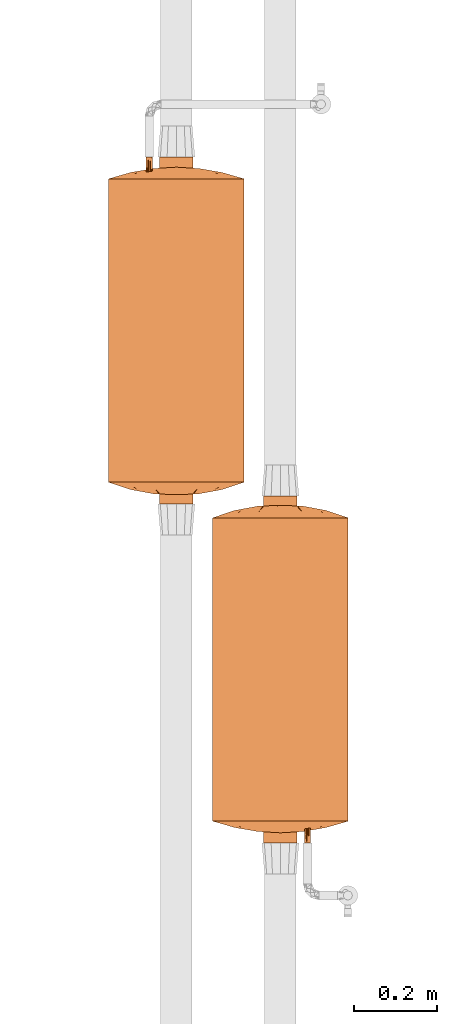
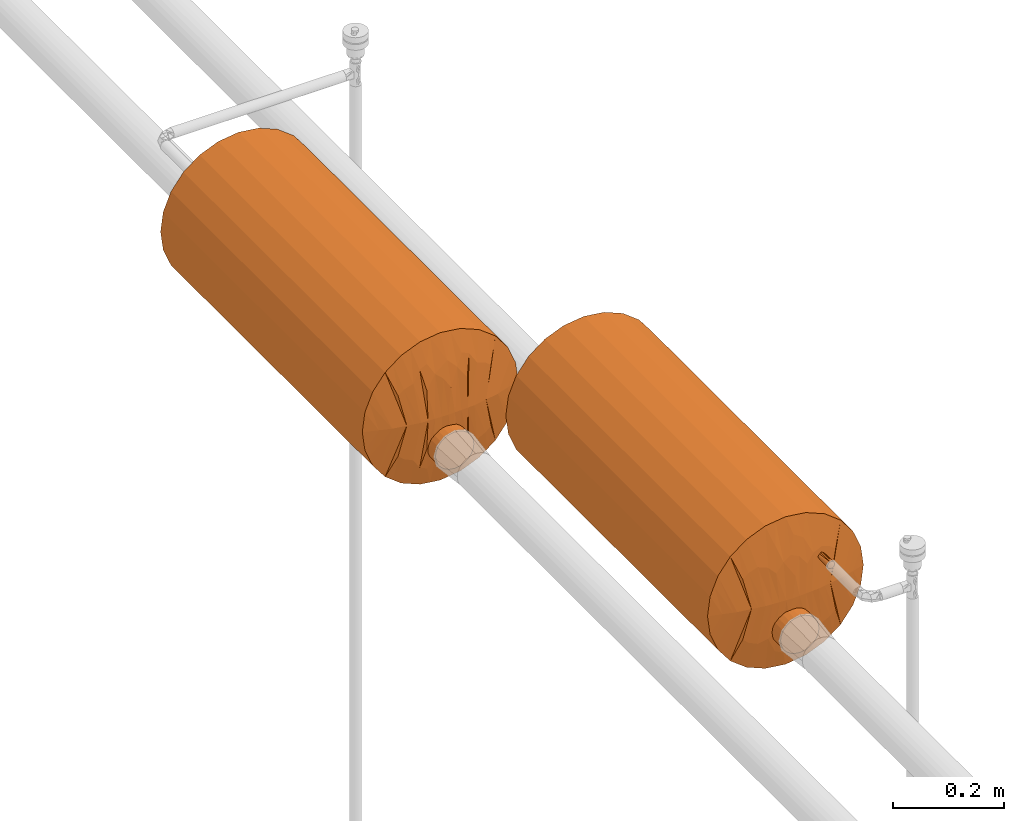
# One storey, part 826 of 827: 2 proxies.
"""IFC2X3 building model written with IfcOpenShell, lengths in millimetres."""

from ifc_helpers import new_model, entity, si_unit, converted_unit, derived_unit, direction, frame, origin, place, context, subcontext, project, spatial, faceted_brep, source, transform, mapped, material, material_list, type_object, type_shapes, element, save


model = new_model("IFC2X3")

# Units and contexts
model_context = context("Model", 3, precision=0.01, world=origin(), true_north=direction((6.12303176911189e-17, 1.0)))
body_context = subcontext(model_context, "Body", "Model", "MODEL_VIEW")
ifc_project = project(units=[si_unit("LENGTHUNIT", "METRE", prefix="MILLI"), si_unit("AREAUNIT", "SQUARE_METRE"), si_unit("VOLUMEUNIT", "CUBIC_METRE"), converted_unit("PLANEANGLEUNIT", "DEGREE", entity("IfcRatioMeasure", 0.0174532925199433), si_unit("PLANEANGLEUNIT", "RADIAN"), dimensions=[0, 0, 0, 0, 0, 0, 0]), si_unit("MASSUNIT", "GRAM", prefix="KILO"), derived_unit("MASSDENSITYUNIT", [(si_unit("MASSUNIT", "GRAM", prefix="KILO"), 1), (si_unit("LENGTHUNIT", "METRE"), -3)]), derived_unit("MOMENTOFINERTIAUNIT", [(si_unit("LENGTHUNIT", "METRE"), 4)]), si_unit("TIMEUNIT", "SECOND"), si_unit("FREQUENCYUNIT", "HERTZ"), si_unit("THERMODYNAMICTEMPERATUREUNIT", "DEGREE_CELSIUS"), derived_unit("THERMALTRANSMITTANCEUNIT", [(si_unit("MASSUNIT", "GRAM", prefix="KILO"), 1), (si_unit("THERMODYNAMICTEMPERATUREUNIT", "KELVIN"), -1), (si_unit("TIMEUNIT", "SECOND"), -3)]), derived_unit("VOLUMETRICFLOWRATEUNIT", [(si_unit("LENGTHUNIT", "METRE"), 3), (si_unit("TIMEUNIT", "SECOND"), -1)]), derived_unit("MASSFLOWRATEUNIT", [(si_unit("MASSUNIT", "GRAM", prefix="KILO"), 1), (si_unit("TIMEUNIT", "SECOND"), -1)]), derived_unit("ROTATIONALFREQUENCYUNIT", [(si_unit("TIMEUNIT", "SECOND"), -1)]), si_unit("ELECTRICCURRENTUNIT", "AMPERE"), si_unit("ELECTRICVOLTAGEUNIT", "VOLT"), si_unit("POWERUNIT", "WATT"), si_unit("FORCEUNIT", "NEWTON", prefix="KILO"), si_unit("ILLUMINANCEUNIT", "LUX"), si_unit("LUMINOUSFLUXUNIT", "LUMEN"), si_unit("LUMINOUSINTENSITYUNIT", "CANDELA"), derived_unit("USERDEFINED", [(si_unit("MASSUNIT", "GRAM", prefix="KILO"), -1), (si_unit("LENGTHUNIT", "METRE"), -2), (si_unit("TIMEUNIT", "SECOND"), 3), (si_unit("LUMINOUSFLUXUNIT", "LUMEN"), 1)]), derived_unit("LINEARVELOCITYUNIT", [(si_unit("LENGTHUNIT", "METRE"), 1), (si_unit("TIMEUNIT", "SECOND"), -1)]), si_unit("PRESSUREUNIT", "PASCAL"), derived_unit("USERDEFINED", [(si_unit("LENGTHUNIT", "METRE"), -2), (si_unit("MASSUNIT", "GRAM", prefix="KILO"), 1), (si_unit("TIMEUNIT", "SECOND"), -2)]), derived_unit("LINEARFORCEUNIT", [(si_unit("MASSUNIT", "GRAM", prefix="KILO"), 1), (si_unit("LENGTHUNIT", "METRE"), 1), (si_unit("TIMEUNIT", "SECOND"), -2), (si_unit("LENGTHUNIT", "METRE"), -1)]), derived_unit("PLANARFORCEUNIT", [(si_unit("MASSUNIT", "GRAM", prefix="KILO"), 1), (si_unit("LENGTHUNIT", "METRE"), 1), (si_unit("TIMEUNIT", "SECOND"), -2), (si_unit("LENGTHUNIT", "METRE"), -2)])], contexts=[model_context])

# Site, building, storey
site_placement = place(None, origin())
site = spatial("IfcSite", under=ifc_project, at=site_placement, CompositionType="ELEMENT")
building_placement = place(site_placement, origin())
building = spatial("IfcBuilding", under=site, at=building_placement, CompositionType="ELEMENT")
storey_placement = place(building_placement, frame((0.0, 0.0, 28200.0)))
storey = spatial("IfcBuildingStorey", under=building, at=storey_placement, Name="08", CompositionType="ELEMENT", Elevation=28200.0)

# Proxies
ifc_material_1 = material()
ifc_material_2 = material()
ifc_material_3 = material()
ifc_material_list = material_list([ifc_material_1, ifc_material_2, ifc_material_3])
building_element_proxy_type = type_object("IfcBuildingElementProxyType", Name=":Dy80", PredefinedType="NOTDEFINED", material=ifc_material_1)
shared_shape = source(origin(), body_context, "Body", "Brep", [
    faceted_brep([(68.75, -416.0, 58.5), (70.3, -416.0, 59.7), (71.5, -416.0, 61.25), (72.24, -416.0, 63.06), (72.5, -416.0, 65.0), (72.24, -416.0, 66.94), (71.5, -416.0, 68.75), (70.3, -416.0, 70.3), (68.75, -416.0, 71.5), (66.94, -416.0, 72.24), (65.0, -416.0, 72.5), (63.06, -416.0, 72.24), (61.25, -416.0, 71.5), (59.7, -416.0, 70.3), (58.5, -416.0, 68.75), (57.76, -416.0, 66.94), (57.5, -416.0, 65.0), (57.76, -416.0, 63.06), (58.5, -416.0, 61.25), (59.7, -416.0, 59.7), (61.25, -416.0, 58.5), (63.06, -416.0, 57.76), (65.0, -416.0, 57.5), (66.94, -416.0, 57.76), (65.0, 0.0, 72.5), (66.94, 0.0, 72.24), (68.75, 0.0, 71.5), (70.3, 0.0, 70.3), (71.5, 0.0, 68.75), (72.24, 0.0, 66.94), (72.5, 0.0, 65.0), (72.24, 0.0, 63.06), (71.5, 0.0, 61.25), (70.3, 0.0, 59.7), (68.75, 0.0, 58.5), (66.94, 0.0, 57.76), (65.0, 0.0, 57.5), (63.06, 0.0, 57.76), (61.25, 0.0, 58.5), (59.7, 0.0, 59.7), (58.5, 0.0, 61.25), (57.76, 0.0, 63.06), (57.5, 0.0, 65.0), (57.76, 0.0, 66.94), (58.5, 0.0, 68.75), (59.7, 0.0, 70.3), (61.25, 0.0, 71.5), (63.06, 0.0, 72.24), (72.5, -320.38, 65.0), (65.49, -181.32, 57.52), (72.5, -95.62, 65.0), (72.5, -208.0, 65.0), (72.5, -224.75, 65.0), (65.0, -272.56, 57.5), (57.5, -320.38, 65.0), (57.5, -224.75, 65.0), (57.5, -208.0, 65.0), (65.0, -84.55, 57.5), (57.5, -95.62, 65.0), (65.0, -84.55, 72.5), (65.0, -272.56, 72.5), (64.51, -181.32, 72.48)], [[[0, 1, 2, 3, 4, 5, 6, 7, 8, 9, 10, 11, 12, 13, 14, 15, 16, 17, 18, 19, 20, 21, 22, 23]], [[24, 25, 26, 27, 28, 29, 30, 31, 32, 33, 34, 35, 36, 37, 38, 39, 40, 41, 42, 43, 44, 45, 46, 47]], [[48, 1, 0]], [[49, 50, 51, 52]], [[53, 54, 55, 56]], [[57, 38, 37]], [[2, 1, 48]], [[36, 57, 37]], [[21, 53, 22]], [[19, 18, 54]], [[58, 40, 39]], [[35, 34, 57]], [[58, 57, 49]], [[58, 42, 41]], [[17, 16, 54]], [[58, 49, 56]], [[18, 17, 54]], [[56, 49, 53]], [[48, 4, 3]], [[31, 30, 50]], [[38, 57, 39]], [[33, 57, 34]], [[53, 52, 48]], [[40, 58, 41]], [[33, 32, 50]], [[49, 57, 50]], [[50, 32, 31]], [[58, 39, 57]], [[52, 53, 49]], [[2, 48, 3]], [[35, 57, 36]], [[22, 53, 23]], [[54, 20, 19]], [[53, 48, 23]], [[0, 23, 48]], [[54, 53, 21]], [[21, 20, 54]], [[33, 50, 57]], [[13, 12, 54]], [[59, 26, 25]], [[14, 13, 54]], [[24, 59, 25]], [[9, 60, 10]], [[50, 28, 27]], [[47, 46, 59]], [[61, 58, 56, 55]], [[60, 55, 54]], [[50, 59, 61]], [[50, 30, 29]], [[5, 4, 48]], [[48, 7, 6]], [[48, 6, 5]], [[54, 16, 15]], [[43, 42, 58]], [[60, 51, 61]], [[50, 61, 51]], [[59, 46, 45]], [[26, 59, 27]], [[45, 44, 58]], [[60, 48, 52, 51]], [[61, 59, 58]], [[58, 44, 43]], [[59, 50, 27]], [[60, 61, 55]], [[14, 54, 15]], [[10, 60, 11]], [[47, 59, 24]], [[48, 8, 7]], [[60, 54, 11]], [[12, 11, 54]], [[9, 48, 60]], [[9, 8, 48]], [[28, 50, 29]], [[45, 58, 59]]]),
    faceted_brep([(10.24, -416.0, -103.64), (19.88, -416.0, -99.64), (28.17, -416.0, -93.28), (34.52, -416.0, -85.0), (38.52, -416.0, -75.35), (39.88, -416.0, -65.0), (38.52, -416.0, -54.65), (34.52, -416.0, -45.0), (28.17, -416.0, -36.72), (19.88, -416.0, -30.36), (10.24, -416.0, -26.36), (-0.12, -416.0, -25.0), (-10.47, -416.0, -26.36), (-20.12, -416.0, -30.36), (-28.4, -416.0, -36.72), (-34.76, -416.0, -45.0), (-38.75, -416.0, -54.65), (-40.12, -416.0, -65.0), (-38.75, -416.0, -75.35), (-34.76, -416.0, -85.0), (-28.4, -416.0, -93.28), (-20.12, -416.0, -99.64), (-10.47, -416.0, -103.64), (-0.12, -416.0, -105.0), (-0.12, 416.0, -25.0), (10.24, 416.0, -26.36), (19.88, 416.0, -30.36), (28.17, 416.0, -36.72), (34.52, 416.0, -45.0), (38.52, 416.0, -54.65), (39.88, 416.0, -65.0), (38.52, 416.0, -75.35), (34.52, 416.0, -85.0), (28.17, 416.0, -93.28), (19.88, 416.0, -99.64), (10.24, 416.0, -103.64), (-0.12, 416.0, -105.0), (-10.47, 416.0, -103.64), (-20.12, 416.0, -99.64), (-28.4, 416.0, -93.28), (-34.76, 416.0, -85.0), (-38.75, 416.0, -75.35), (-40.12, 416.0, -65.0), (-38.75, 416.0, -54.65), (-34.76, 416.0, -45.0), (-28.4, 416.0, -36.72), (-20.12, 416.0, -30.36), (-10.47, 416.0, -26.36), (-37.07, 0.0, -80.31), (-15.42, 0.0, -101.96), (-5.34, -184.0, -104.66), (-24.47, -103.67, -96.73), (-31.85, -184.0, -89.35), (-31.85, 103.67, -89.35), (-24.47, 184.0, -96.73), (24.23, 103.67, -96.73), (31.62, 184.0, -89.35), (24.23, -184.0, -96.73), (31.62, -103.67, -89.35), (-5.34, 103.67, -104.66), (-39.35, 138.45, -72.8), (-40.12, 0.0, -65.0), (-39.41, -146.88, -72.49), (5.1, -103.67, -104.66), (5.1, 184.0, -104.66), (15.19, 0.0, -101.96), (36.84, 0.0, -80.31), (39.88, 0.0, -65.0), (39.17, 146.88, -72.49), (39.11, -138.45, -72.8), (39.88, -25.67, -65.0), (24.23, -184.0, -33.27), (31.62, 0.0, -40.65), (36.84, 184.0, -49.69), (15.19, 0.0, -28.04), (24.23, 103.67, -33.27), (-24.47, 103.67, -33.27), (-31.85, 184.0, -40.65), (-24.47, -184.0, -33.27), (-31.85, -103.67, -40.65), (5.1, 103.67, -25.34), (39.15, -107.63, -57.39), (39.29, 153.03, -58.11), (36.84, -103.67, -49.69), (5.1, -184.0, -25.34), (-15.42, 0.0, -28.04), (-5.34, 184.0, -25.34), (-5.34, -103.67, -25.34), (-37.07, 0.0, -49.69), (-39.41, 146.88, -57.51), (-39.35, -138.45, -57.2)], [[[0, 1, 2, 3, 4, 5, 6, 7, 8, 9, 10, 11, 12, 13, 14, 15, 16, 17, 18, 19, 20, 21, 22, 23]], [[24, 25, 26, 27, 28, 29, 30, 31, 32, 33, 34, 35, 36, 37, 38, 39, 40, 41, 42, 43, 44, 45, 46, 47]], [[48, 41, 40]], [[49, 50, 22]], [[51, 52, 53, 54]], [[40, 53, 48]], [[49, 38, 37]], [[55, 33, 56]], [[57, 58, 2]], [[54, 49, 51]], [[48, 52, 19]], [[59, 49, 37]], [[41, 48, 60]], [[17, 61, 62]], [[41, 60, 42]], [[40, 39, 53]], [[51, 21, 20]], [[19, 18, 48]], [[63, 0, 23]], [[48, 53, 52]], [[21, 51, 49]], [[34, 33, 55]], [[22, 21, 49]], [[37, 36, 59]], [[49, 59, 50]], [[63, 50, 59, 64]], [[65, 35, 34]], [[59, 36, 64]], [[50, 63, 23]], [[34, 55, 65]], [[66, 32, 31]], [[33, 32, 56]], [[53, 39, 54]], [[56, 66, 58]], [[1, 57, 2]], [[30, 67, 68]], [[65, 0, 63]], [[1, 0, 65]], [[39, 38, 54]], [[58, 3, 2]], [[61, 60, 62]], [[65, 55, 57]], [[22, 50, 23]], [[66, 3, 58]], [[3, 66, 4]], [[36, 35, 64]], [[66, 69, 4]], [[19, 52, 20]], [[52, 51, 20]], [[65, 63, 64]], [[67, 69, 68]], [[69, 5, 4]], [[49, 54, 38]], [[65, 57, 1]], [[58, 57, 55, 56]], [[65, 64, 35]], [[66, 56, 32]], [[62, 48, 18]], [[42, 60, 61]], [[48, 62, 60]], [[17, 62, 18]], [[68, 66, 31]], [[69, 67, 70, 5]], [[66, 68, 69]], [[30, 68, 31]], [[9, 8, 71]], [[72, 73, 28]], [[74, 71, 75]], [[27, 72, 28]], [[74, 26, 25]], [[76, 45, 77]], [[78, 79, 14]], [[72, 27, 75]], [[72, 71, 8]], [[80, 74, 25]], [[5, 70, 81]], [[29, 73, 82]], [[46, 45, 76]], [[27, 26, 75]], [[83, 7, 6]], [[72, 7, 83]], [[72, 83, 73]], [[8, 7, 72]], [[71, 72, 75]], [[25, 24, 80]], [[10, 9, 74]], [[82, 30, 29]], [[74, 80, 84]], [[83, 81, 82]], [[85, 47, 46]], [[80, 24, 86]], [[84, 87, 11]], [[46, 76, 85]], [[88, 44, 43]], [[45, 44, 77]], [[10, 84, 11]], [[77, 88, 79]], [[13, 78, 14]], [[42, 61, 89]], [[85, 12, 87]], [[13, 12, 85]], [[79, 15, 14]], [[90, 17, 16]], [[74, 9, 71]], [[85, 76, 78]], [[28, 73, 29]], [[88, 15, 79]], [[15, 88, 16]], [[82, 81, 70]], [[88, 90, 16]], [[26, 74, 75]], [[24, 47, 86]], [[85, 87, 86]], [[61, 90, 89]], [[87, 12, 11]], [[83, 82, 73]], [[82, 70, 67, 30]], [[83, 6, 81]], [[5, 81, 6]], [[74, 84, 10]], [[87, 84, 80, 86]], [[85, 78, 13]], [[79, 78, 76]], [[85, 86, 47]], [[88, 77, 44]], [[76, 77, 79]], [[89, 88, 43]], [[17, 90, 61]], [[88, 89, 90]], [[42, 89, 43]]]),
    faceted_brep([(-155.82, -365.93, 0.0), (-162.5, -364.0, 0.0), (-161.1, -364.0, -10.66), (-159.69, -364.0, -21.32), (-156.96, -364.0, -42.06), (-135.8, -371.72, 0.0), (-149.15, -367.86, 0.0), (-55.09, -388.69, 0.0), (-68.69, -386.35, 0.0), (-85.05, -378.12, -76.87), (-140.73, -364.0, -81.25), (-109.48, -379.34, 0.0), (-144.79, -364.0, -71.45), (-98.08, -364.0, -127.82), (-96.75, -377.52, -65.95), (-114.9, -364.0, -114.9), (-67.08, -379.71, -84.46), (-82.29, -384.01, 0.0), (-95.89, -381.68, 0.0), (-116.06, -377.43, 0.0), (-122.64, -375.53, 0.0), (-127.82, -364.0, -98.08), (-47.38, -383.12, -78.27), (-41.32, -389.51, 0.0), (82.29, -384.01, 0.0), (114.9, -364.0, -114.9), (95.89, -381.68, 0.0), (-32.54, -386.74, -62.05), (-27.55, -390.33, 0.0), (-81.25, -364.0, -140.73), (161.1, -364.0, -10.66), (162.5, -364.0, 0.0), (155.82, -365.93, 0.0), (149.15, -367.86, 0.0), (135.8, -371.72, 0.0), (156.96, -364.0, -42.06), (159.69, -364.0, -21.32), (-16.83, -384.52, -82.16), (-0.45, -383.35, -90.28), (-6.63, -389.75, -44.58), (81.25, -364.0, -140.73), (85.05, -378.12, -76.87), (67.08, -379.71, -84.46), (148.85, -364.0, -61.65), (116.06, -377.43, 0.0), (140.73, -364.0, -81.25), (96.75, -377.52, -65.95), (68.69, -386.35, 0.0), (109.48, -379.34, 0.0), (127.82, -364.0, -98.08), (-148.85, -364.0, -61.65), (122.64, -375.53, 0.0), (-10.64, -374.91, -126.77), (-29.41, -377.03, -115.39), (-21.03, -364.0, -159.73), (-61.65, -364.0, -148.85), (-42.06, -364.0, -156.96), (0.0, -364.0, -162.5), (28.0, -377.32, -114.56), (32.15, -386.68, -62.66), (15.85, -384.77, -80.88), (-13.77, -391.14, 0.0), (47.38, -383.12, -78.27), (41.32, -389.51, 0.0), (13.77, -391.14, 0.0), (98.08, -364.0, -127.82), (55.09, -388.69, 0.0), (27.55, -390.33, 0.0), (61.65, -364.0, -148.85), (42.06, -364.0, -156.96), (0.0, -391.96, 0.0), (21.03, -364.0, -159.73), (161.1, -364.0, 10.66), (159.69, -364.0, 21.32), (156.96, -364.0, 42.06), (85.05, -378.12, 76.87), (140.73, -364.0, 81.25), (144.79, -364.0, 71.45), (98.08, -364.0, 127.82), (96.75, -377.52, 65.95), (114.9, -364.0, 114.9), (67.08, -379.71, 84.46), (127.82, -364.0, 98.08), (47.38, -383.12, 78.27), (-114.9, -364.0, 114.9), (32.54, -386.74, 62.05), (81.25, -364.0, 140.73), (-156.96, -364.0, 42.06), (-159.69, -364.0, 21.32), (-161.1, -364.0, 10.66), (16.83, -384.52, 82.16), (0.45, -383.35, 90.28), (6.63, -389.75, 44.58), (-81.25, -364.0, 140.73), (-85.05, -378.12, 76.87), (-67.08, -379.71, 84.46), (-148.85, -364.0, 61.65), (-140.73, -364.0, 81.25), (-96.75, -377.52, 65.95), (-127.82, -364.0, 98.08), (148.85, -364.0, 61.65), (10.64, -374.91, 126.77), (29.41, -377.03, 115.39), (21.03, -364.0, 159.73), (61.65, -364.0, 148.85), (42.06, -364.0, 156.96), (0.0, -364.0, 162.5), (-28.0, -377.32, 114.56), (-32.15, -386.68, 62.66), (-15.85, -384.77, 80.88), (-47.38, -383.12, 78.27), (-98.08, -364.0, 127.82), (-61.65, -364.0, 148.85), (-42.06, -364.0, 156.96), (-21.03, -364.0, 159.73), (0.0, -364.0, 0.0)], [[[0, 1, 2, 3, 4, 5, 6]], [[7, 8, 9]], [[10, 11, 12]], [[13, 14, 15]], [[16, 7, 9]], [[15, 17, 18]], [[12, 11, 19, 20]], [[18, 21, 15]], [[22, 23, 16]], [[24, 25, 26]], [[22, 27, 28]], [[29, 16, 9]], [[29, 9, 13]], [[30, 31, 32, 33, 34, 35, 36]], [[13, 9, 14]], [[8, 14, 9]], [[37, 38, 39]], [[10, 21, 11]], [[40, 41, 42]], [[43, 44, 45]], [[11, 21, 18]], [[46, 25, 24]], [[47, 41, 46]], [[48, 49, 45]], [[34, 43, 35]], [[45, 44, 48]], [[20, 50, 12]], [[4, 50, 5]], [[43, 34, 51, 44]], [[5, 50, 20]], [[38, 37, 52]], [[26, 25, 49]], [[49, 48, 26]], [[52, 53, 54]], [[22, 55, 56]], [[22, 16, 55]], [[23, 22, 28]], [[23, 7, 16]], [[54, 57, 52]], [[58, 59, 60]], [[37, 61, 27]], [[62, 42, 63]], [[38, 57, 60]], [[60, 64, 39]], [[65, 46, 41]], [[40, 65, 41]], [[47, 66, 41]], [[42, 41, 66]], [[63, 67, 62]], [[62, 68, 42]], [[42, 66, 63]], [[59, 62, 67]], [[8, 17, 14]], [[16, 29, 55]], [[68, 62, 69]], [[68, 40, 42]], [[15, 14, 17]], [[25, 46, 65]], [[24, 47, 46]], [[53, 37, 27]], [[53, 22, 56]], [[37, 39, 61]], [[61, 28, 27]], [[22, 53, 27]], [[56, 54, 53]], [[62, 59, 58]], [[53, 52, 37]], [[57, 38, 52]], [[59, 64, 60]], [[60, 39, 38]], [[61, 39, 70]], [[60, 57, 71]], [[64, 59, 67]], [[70, 39, 64]], [[58, 60, 71]], [[71, 69, 58]], [[62, 58, 69]], [[32, 31, 72, 73, 74, 34, 33]], [[66, 47, 75]], [[76, 48, 77]], [[78, 79, 80]], [[81, 66, 75]], [[80, 24, 26]], [[77, 48, 44, 51]], [[26, 82, 80]], [[83, 63, 81]], [[17, 84, 18]], [[83, 85, 67]], [[86, 81, 75]], [[86, 75, 78]], [[0, 6, 5, 87, 88, 89, 1]], [[78, 75, 79]], [[47, 79, 75]], [[90, 91, 92]], [[76, 82, 48]], [[93, 94, 95]], [[96, 19, 97]], [[48, 82, 26]], [[98, 84, 17]], [[8, 94, 98]], [[11, 99, 97]], [[5, 96, 87]], [[97, 19, 11]], [[51, 100, 77]], [[74, 100, 34]], [[96, 5, 20, 19]], [[34, 100, 51]], [[91, 90, 101]], [[18, 84, 99]], [[99, 11, 18]], [[101, 102, 103]], [[83, 104, 105]], [[83, 81, 104]], [[63, 83, 67]], [[63, 66, 81]], [[103, 106, 101]], [[107, 108, 109]], [[90, 64, 85]], [[110, 95, 23]], [[91, 106, 109]], [[109, 61, 92]], [[111, 98, 94]], [[93, 111, 94]], [[8, 7, 94]], [[95, 94, 7]], [[23, 28, 110]], [[110, 112, 95]], [[95, 7, 23]], [[108, 110, 28]], [[47, 24, 79]], [[81, 86, 104]], [[112, 110, 113]], [[112, 93, 95]], [[80, 79, 24]], [[84, 98, 111]], [[17, 8, 98]], [[102, 90, 85]], [[102, 83, 105]], [[90, 92, 64]], [[64, 67, 85]], [[83, 102, 85]], [[105, 103, 102]], [[110, 108, 107]], [[102, 101, 90]], [[106, 91, 101]], [[108, 61, 109]], [[109, 92, 91]], [[64, 92, 70]], [[109, 106, 114]], [[61, 108, 28]], [[70, 92, 61]], [[107, 109, 114]], [[114, 113, 107]], [[110, 107, 113]], [[115, 31, 30]], [[115, 30, 36]], [[115, 36, 35]], [[115, 35, 43]], [[115, 43, 45]], [[115, 45, 49]], [[115, 49, 25]], [[115, 25, 65]], [[115, 65, 40]], [[115, 40, 68]], [[115, 68, 69]], [[115, 69, 71]], [[115, 71, 57]], [[115, 57, 54]], [[115, 54, 56]], [[115, 56, 55]], [[115, 55, 29]], [[115, 29, 13]], [[115, 13, 15]], [[115, 15, 21]], [[115, 21, 10]], [[115, 10, 12]], [[115, 12, 50]], [[115, 50, 4]], [[115, 4, 3]], [[115, 3, 2]], [[115, 2, 1]], [[115, 1, 89]], [[115, 72, 31]], [[115, 73, 72]], [[115, 74, 73]], [[115, 100, 74]], [[115, 77, 100]], [[115, 76, 77]], [[115, 82, 76]], [[115, 80, 82]], [[115, 78, 80]], [[115, 86, 78]], [[115, 104, 86]], [[115, 105, 104]], [[115, 103, 105]], [[115, 106, 103]], [[115, 89, 88]], [[115, 88, 87]], [[115, 87, 96]], [[115, 96, 97]], [[115, 97, 99]], [[115, 99, 84]], [[115, 84, 111]], [[115, 111, 93]], [[115, 93, 112]], [[115, 112, 113]], [[115, 113, 114]], [[115, 114, 106]]]),
    faceted_brep([(-69.03, 389.19, 0.0), (-85.06, 380.44, -76.61), (-96.96, 379.53, -66.85), (-151.96, 367.54, 0.0), (-146.69, 369.31, 0.0), (-141.41, 371.08, 0.0), (-133.54, 373.72, 0.0), (-156.96, 364.0, -42.06), (-158.62, 364.0, -29.46), (-159.45, 364.0, -23.17), (-160.28, 364.0, -16.87), (-162.5, 364.0, 0.0), (-42.06, 364.0, -156.96), (-51.54, 378.96, -108.11), (-36.26, 378.67, -115.22), (-66.57, 382.24, -84.52), (-55.4, 391.71, 0.0), (-41.55, 392.28, 0.0), (156.96, 364.0, -42.06), (133.54, 373.72, 0.0), (141.41, 371.08, 0.0), (146.69, 369.31, 0.0), (151.96, 367.54, 0.0), (162.5, 364.0, 0.0), (160.28, 364.0, -16.87), (159.45, 364.0, -23.17), (158.62, 364.0, -29.46), (-140.73, 364.0, -81.25), (-148.85, 364.0, -61.65), (-109.93, 381.64, 0.0), (-127.82, 364.0, -98.08), (109.93, 381.64, 0.0), (148.85, 364.0, -61.65), (140.73, 364.0, -81.25), (-114.9, 364.0, -114.9), (-82.67, 386.68, 0.0), (-125.67, 376.36, 0.0), (51.54, 378.96, -108.11), (41.55, 392.28, 0.0), (66.57, 382.24, -84.52), (114.9, 364.0, -114.9), (96.3, 384.16, 0.0), (127.82, 364.0, -98.08), (125.67, 376.36, 0.0), (81.25, 364.0, -140.73), (85.06, 380.44, -76.61), (-96.3, 384.16, 0.0), (98.08, 364.0, -127.82), (69.03, 389.19, 0.0), (96.96, 379.53, -66.85), (82.67, 386.68, 0.0), (7.51, 388.27, -79.01), (0.0, 394.0, 0.0), (13.85, 393.43, 0.0), (-98.08, 364.0, -127.82), (-81.25, 364.0, -140.73), (-61.65, 364.0, -148.85), (-22.95, 385.16, -92.34), (-13.85, 393.43, 0.0), (-7.04, 391.55, -56.37), (-27.7, 392.85, 0.0), (-42.17, 388.61, -64.85), (55.4, 391.71, 0.0), (36.26, 378.67, -115.22), (42.17, 388.61, -64.85), (61.65, 364.0, -148.85), (-21.03, 364.0, -159.73), (42.06, 364.0, -156.96), (21.03, 364.0, -159.73), (22.95, 385.16, -92.34), (-4.64, 381.32, -111.09), (0.0, 364.0, -162.5), (28.55, 391.9, -45.49), (27.7, 392.85, 0.0), (85.06, 380.44, 76.61), (96.96, 379.53, 66.85), (156.96, 364.0, 42.06), (158.62, 364.0, 29.46), (159.45, 364.0, 23.17), (160.28, 364.0, 16.87), (-148.85, 364.0, 61.65), (-140.73, 364.0, 81.25), (42.06, 364.0, 156.96), (51.54, 378.96, 108.11), (36.26, 378.67, 115.22), (66.57, 382.24, 84.52), (140.73, 364.0, 81.25), (148.85, 364.0, 61.65), (127.82, 364.0, 98.08), (-156.96, 364.0, 42.06), (-160.28, 364.0, 16.87), (-159.45, 364.0, 23.17), (-158.62, 364.0, 29.46), (-96.96, 379.53, 66.85), (-85.06, 380.44, 76.61), (114.9, 364.0, 114.9), (-51.54, 378.96, 108.11), (-66.57, 382.24, 84.52), (-114.9, 364.0, 114.9), (-127.82, 364.0, 98.08), (-81.25, 364.0, 140.73), (-98.08, 364.0, 127.82), (-42.17, 388.61, 64.85), (-22.95, 385.16, 92.34), (-36.26, 378.67, 115.22), (-61.65, 364.0, 148.85), (98.08, 364.0, 127.82), (81.25, 364.0, 140.73), (61.65, 364.0, 148.85), (-7.04, 391.55, 56.37), (-42.06, 364.0, 156.96), (42.17, 388.61, 64.85), (-21.03, 364.0, 159.73), (7.51, 388.27, 79.01), (-4.64, 381.32, 111.09), (22.95, 385.16, 92.34), (21.03, 364.0, 159.73), (0.0, 364.0, 162.5), (0.0, 364.0, 0.0)], [[[0, 1, 2]], [[3, 4, 5, 6, 7, 8, 9, 10, 11]], [[12, 13, 14]], [[15, 16, 17]], [[15, 1, 16]], [[18, 19, 20, 21, 22, 23, 24, 25, 26]], [[27, 28, 29]], [[29, 30, 27]], [[6, 28, 7]], [[31, 32, 33]], [[2, 34, 35]], [[6, 36, 29, 28]], [[32, 19, 18]], [[37, 38, 39]], [[40, 41, 42]], [[31, 43, 19, 32]], [[44, 39, 45]], [[30, 29, 46]], [[44, 45, 47]], [[48, 49, 45]], [[40, 50, 41]], [[51, 52, 53]], [[46, 34, 30]], [[35, 34, 46]], [[31, 42, 41]], [[33, 42, 31]], [[54, 2, 1]], [[55, 54, 1]], [[0, 16, 1]], [[13, 12, 56]], [[57, 58, 59]], [[55, 1, 15]], [[13, 56, 15]], [[47, 45, 49]], [[17, 60, 61]], [[47, 49, 40]], [[39, 62, 45]], [[62, 48, 45]], [[37, 63, 64]], [[39, 44, 65]], [[39, 65, 37]], [[17, 13, 15]], [[38, 62, 39]], [[56, 55, 15]], [[61, 57, 14]], [[61, 60, 57]], [[57, 66, 14]], [[63, 37, 67]], [[37, 65, 67]], [[37, 64, 38]], [[63, 68, 69]], [[70, 57, 59]], [[34, 2, 54]], [[35, 0, 2]], [[48, 50, 49]], [[40, 49, 50]], [[61, 14, 13]], [[17, 61, 13]], [[57, 70, 66]], [[66, 12, 14]], [[57, 60, 58]], [[71, 70, 68]], [[69, 72, 64]], [[63, 67, 68]], [[69, 64, 63]], [[38, 64, 73]], [[72, 51, 53]], [[59, 58, 52]], [[69, 68, 70]], [[51, 70, 59]], [[73, 72, 53]], [[66, 70, 71]], [[51, 59, 52]], [[69, 70, 51]], [[64, 72, 73]], [[51, 72, 69]], [[48, 74, 75]], [[22, 21, 20, 19, 76, 77, 78, 79, 23]], [[29, 80, 81]], [[82, 83, 84]], [[85, 62, 38]], [[85, 74, 62]], [[86, 87, 31]], [[31, 88, 86]], [[19, 87, 76]], [[89, 6, 5, 4, 3, 11, 90, 91, 92]], [[0, 93, 94]], [[75, 95, 50]], [[88, 31, 41]], [[19, 43, 31, 87]], [[96, 17, 97]], [[98, 46, 99]], [[80, 6, 89]], [[100, 97, 94]], [[98, 35, 46]], [[100, 94, 101]], [[6, 80, 29, 36]], [[60, 102, 103]], [[41, 95, 88]], [[50, 95, 41]], [[29, 99, 46]], [[81, 99, 29]], [[101, 94, 93]], [[101, 93, 98]], [[97, 16, 94]], [[16, 0, 94]], [[96, 104, 102]], [[97, 100, 105]], [[97, 105, 96]], [[106, 75, 74]], [[17, 16, 97]], [[107, 106, 74]], [[48, 62, 74]], [[83, 82, 108]], [[109, 52, 58]], [[107, 74, 85]], [[83, 108, 85]], [[104, 96, 110]], [[38, 73, 111]], [[96, 105, 110]], [[96, 102, 17]], [[104, 112, 103]], [[113, 109, 114]], [[38, 83, 85]], [[108, 107, 85]], [[111, 115, 84]], [[113, 53, 52]], [[115, 116, 84]], [[0, 35, 93]], [[98, 93, 35]], [[95, 75, 106]], [[50, 48, 75]], [[117, 114, 112]], [[109, 58, 103]], [[104, 110, 112]], [[103, 102, 104]], [[17, 102, 60]], [[111, 84, 83]], [[38, 111, 83]], [[115, 114, 116]], [[116, 82, 84]], [[115, 111, 73]], [[114, 109, 103]], [[58, 60, 103]], [[115, 73, 53]], [[112, 114, 103]], [[109, 113, 52]], [[114, 117, 116]], [[114, 115, 113]], [[53, 113, 115]], [[118, 18, 26]], [[118, 26, 25]], [[118, 25, 24]], [[118, 24, 23]], [[118, 23, 79]], [[118, 32, 18]], [[118, 33, 32]], [[118, 42, 33]], [[118, 40, 42]], [[118, 47, 40]], [[118, 44, 47]], [[118, 65, 44]], [[118, 67, 65]], [[118, 68, 67]], [[118, 71, 68]], [[118, 66, 71]], [[118, 12, 66]], [[118, 56, 12]], [[118, 55, 56]], [[118, 54, 55]], [[118, 34, 54]], [[118, 30, 34]], [[118, 27, 30]], [[118, 28, 27]], [[118, 7, 28]], [[118, 8, 7]], [[118, 9, 8]], [[118, 10, 9]], [[118, 11, 10]], [[118, 79, 78]], [[118, 78, 77]], [[118, 77, 76]], [[118, 76, 87]], [[118, 87, 86]], [[118, 86, 88]], [[118, 88, 95]], [[118, 95, 106]], [[118, 106, 107]], [[118, 107, 108]], [[118, 108, 82]], [[118, 82, 116]], [[118, 116, 117]], [[118, 117, 112]], [[118, 90, 11]], [[118, 91, 90]], [[118, 92, 91]], [[118, 89, 92]], [[118, 80, 89]], [[118, 81, 80]], [[118, 99, 81]], [[118, 98, 99]], [[118, 101, 98]], [[118, 100, 101]], [[118, 105, 100]], [[118, 110, 105]], [[118, 112, 110]]]),
    faceted_brep([(81.25, -364.0, -140.73), (114.9, -364.0, -114.9), (140.73, -364.0, -81.25), (156.96, -364.0, -42.06), (162.5, -364.0, 0.0), (156.96, -364.0, 42.06), (140.73, -364.0, 81.25), (114.9, -364.0, 114.9), (81.25, -364.0, 140.73), (42.06, -364.0, 156.96), (0.0, -364.0, 162.5), (-42.06, -364.0, 156.96), (-81.25, -364.0, 140.73), (-114.9, -364.0, 114.9), (-140.73, -364.0, 81.25), (-156.96, -364.0, 42.06), (-162.5, -364.0, 0.0), (-156.96, -364.0, -42.06), (-140.73, -364.0, -81.25), (-114.9, -364.0, -114.9), (-81.25, -364.0, -140.73), (-42.06, -364.0, -156.96), (0.0, -364.0, -162.5), (42.06, -364.0, -156.96), (114.9, 364.0, 114.9), (140.73, 364.0, 81.25), (156.96, 364.0, 42.06), (162.5, 364.0, 0.0), (156.96, 364.0, -42.06), (140.73, 364.0, -81.25), (114.9, 364.0, -114.9), (81.25, 364.0, -140.73), (42.06, 364.0, -156.96), (0.0, 364.0, -162.5), (-42.06, 364.0, -156.96), (-81.25, 364.0, -140.73), (-114.9, 364.0, -114.9), (-140.73, 364.0, -81.25), (-156.96, 364.0, -42.06), (-162.5, 364.0, 0.0), (-156.96, 364.0, 42.06), (-140.73, 364.0, 81.25), (-114.9, 364.0, 114.9), (-81.25, 364.0, 140.73), (-42.06, 364.0, 156.96), (0.0, 364.0, 162.5), (42.06, 364.0, 156.96), (81.25, 364.0, 140.73)], [[[0, 1, 2, 3, 4, 5, 6, 7, 8, 9, 10, 11, 12, 13, 14, 15, 16, 17, 18, 19, 20, 21, 22, 23]], [[24, 25, 26, 27, 28, 29, 30, 31, 32, 33, 34, 35, 36, 37, 38, 39, 40, 41, 42, 43, 44, 45, 46, 47]], [[17, 38, 37, 18]], [[36, 19, 18, 37]], [[20, 35, 34, 21]], [[36, 35, 20, 19]], [[21, 34, 33, 22]], [[38, 17, 16, 39]], [[23, 32, 31, 0]], [[30, 1, 0, 31]], [[2, 29, 28, 3]], [[30, 29, 2, 1]], [[3, 28, 27, 4]], [[32, 23, 22, 33]], [[6, 25, 24, 7]], [[8, 47, 46, 9]], [[24, 47, 8, 7]], [[45, 10, 9, 46]], [[4, 27, 26, 5]], [[26, 25, 6, 5]], [[11, 44, 43, 12]], [[42, 13, 12, 43]], [[14, 41, 40, 15]], [[42, 41, 14, 13]], [[15, 40, 39, 16]], [[44, 11, 10, 45]]]),
])
type_shapes(building_element_proxy_type, [shared_shape])
proxy_1_placement = place(storey_placement, frame((26194.03, 16584.0, 3065.0)))
element("IfcBuildingElementProxy", 1, at=proxy_1_placement, inside=storey, type_object=building_element_proxy_type, material=ifc_material_list, Name=":Dy80", ObjectType=":Dy80", context=body_context, shape_type="MappedRepresentation", body=[
    mapped(shared_shape, transform((0.0, 0.0, 0.0), scale=1.0)),
])
proxy_2_placement = place(storey_placement, frame((25944.17, 17397.3, 3065.0), z_axis=(0.0, 0.0, 1.0), x_axis=(-1.0, 0.0, 0.0)))
element("IfcBuildingElementProxy", 2, at=proxy_2_placement, inside=storey, type_object=building_element_proxy_type, material=ifc_material_list, Name=":Dy80", ObjectType=":Dy80", context=body_context, shape_type="MappedRepresentation", body=[
    mapped(shared_shape, transform((0.0, 0.0, 0.0), scale=1.0)),
])

save(model, "model.ifc")
